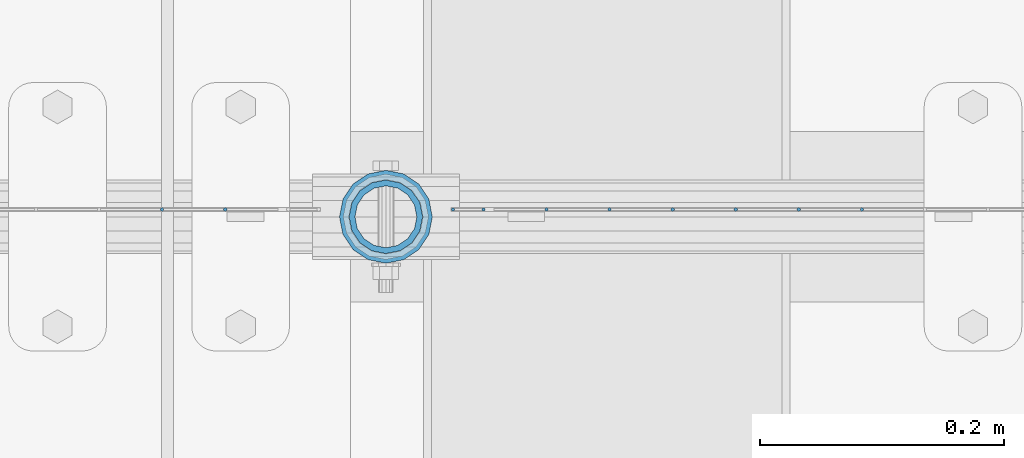
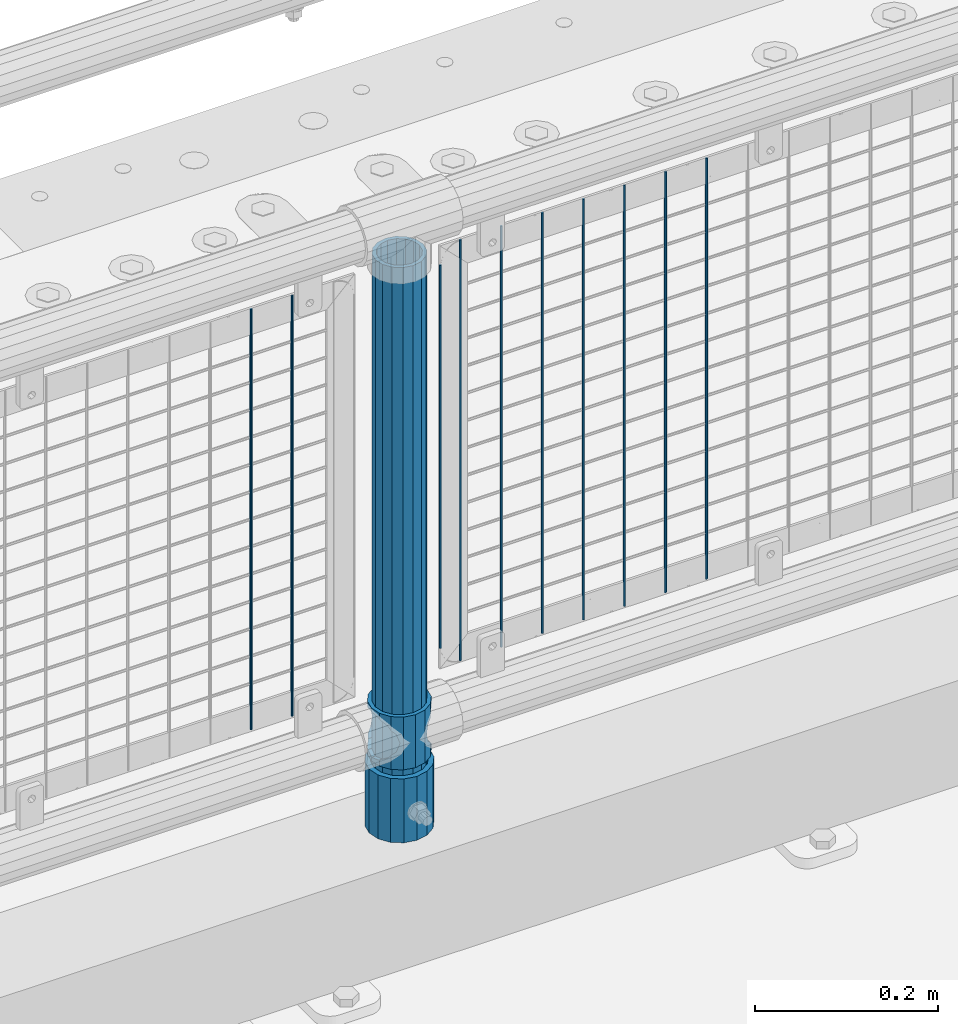
# One storey, part 86 of 219: 13 columns.
"""IFC2X3 building model written with IfcOpenShell, lengths in millimetres."""

from ifc_helpers import new_model, si_unit, frame, origin_with_axes, place, context, subcontext, project, spatial, faceted_brep, material, type_object, element, save


model = new_model("IFC2X3")

# Units and contexts
model_context = context("Model", 3, precision=1e-05, world=origin_with_axes())
body_context = subcontext(model_context, "Body", "Model", "MODEL_VIEW")
ifc_project = project(units=[si_unit("LENGTHUNIT", "METRE", prefix="MILLI"), si_unit("AREAUNIT", "SQUARE_METRE"), si_unit("VOLUMEUNIT", "CUBIC_METRE"), si_unit("MASSUNIT", "GRAM", prefix="KILO"), si_unit("TIMEUNIT", "SECOND"), si_unit("PLANEANGLEUNIT", "RADIAN"), si_unit("SOLIDANGLEUNIT", "STERADIAN"), si_unit("THERMODYNAMICTEMPERATUREUNIT", "DEGREE_CELSIUS"), si_unit("LUMINOUSINTENSITYUNIT", "LUMEN")], contexts=[model_context])

# Site, building, storey
site_placement = place(None, origin_with_axes())
site = spatial("IfcSite", under=ifc_project, at=site_placement, CompositionType="ELEMENT")
building_placement = place(site_placement, origin_with_axes())
building = spatial("IfcBuilding", under=site, at=building_placement, Name="Standard", CompositionType="ELEMENT")
storey_placement = place(building_placement, origin_with_axes())
storey = spatial("IfcBuildingStorey", under=building, at=storey_placement, Name="Undefined", CompositionType="ELEMENT", Elevation=0.0)

# Columns
ifc_material_1 = material(Name="Misc_Undefined")
column_type_1 = type_object("IfcColumnType", PredefinedType="NOTDEFINED")
column_1_placement = place(storey_placement, frame((10569.0, 31664.5, 263.02), z_axis=(-1.0, 0.0, 0.0), x_axis=(0.0, 0.0, 1.0)))
element("IfcColumn", 1, at=column_1_placement, inside=storey, type_object=column_type_1, material=ifc_material_1, context=body_context, shape_type="Brep", body=[
    faceted_brep([(56.6106908090114, 21.46069080901, -21.4606908090118), (56.6106908090114, 21.46069080901, -27.1226768591096), (61.9623795176703, 13.4513226476338, -32.4743655677721), (63.1897438117172, 11.614442172282, -32.8397438117172), (63.1897438117172, 11.614442172282, -28.0397438117179), (46.7644421722801, 28.0397438117179, -11.6144421722802), (46.7644421722801, 28.0397438117179, -20.0882031229849), (51.5310424080006, 24.8548033587067, -24.8548033587067), (35.1499999999996, 30.35, 0.0), (35.1499999999996, 30.3499999999985, -16.6306603983739), (23.5355578277192, 28.0397438117179, -11.6144421722802), (23.5355578277192, 28.0397438117179, -20.0882031229849), (13.6893091909879, 21.46069080901, -21.4606908090118), (13.6893091909879, 21.46069080901, -27.1226768591096), (18.7689575919987, 24.8548033587067, -24.8548033587067), (7.11025618828211, 11.614442172282, -28.0397438117179), (7.11025618828211, 11.614442172282, -32.8397438117172), (8.33762048232455, 13.4513226476338, -32.4743655677721), (4.79999999999961, 0.0, -30.3500000000004), (4.79999999999961, 0.0, -35.1499999999996), (7.11025618828211, -11.614442172282, -28.0397438117179), (7.11025618828211, -11.614442172282, -32.839743811719), (13.6893091909879, -21.46069080901, -21.4606908090118), (13.6893091909879, -21.46069080901, -27.1226768591077), (8.33762048232455, -13.4513226476338, -32.4743655677721), (23.5355578277191, -28.0397438117179, -11.6144421722802), (23.5355578277191, -28.0397438117179, -20.0882031229739), (18.7689575919921, -24.8548033587067, -24.8548033587067), (35.1499999999996, -30.35, 0.0), (35.1499999999996, -30.3499999999985, -16.6306603983649), (46.7644421722801, -28.0397438117179, -11.6144421722802), (46.7644421722801, -28.0397438117179, -20.0882031229739), (56.6106908090114, -21.46069080901, -21.4606908090118), (56.6106908090114, -21.46069080901, -27.1226768591077), (51.5310424080006, -24.8548033587067, -24.8548033587067), (63.1897438117172, -11.614442172282, -28.0397438117179), (63.1897438117172, -11.614442172282, -32.839743811719), (61.9623795176747, -13.4513226476338, -32.4743655677721), (65.4999999999997, 0.0, -30.3500000000004), (65.4999999999997, 0.0, -35.1499999999996), (0.0, -28.0397438117179, -11.6144421722802), (0.0, -30.3499999999985, 0.0), (0.0, -21.46069080901, -21.4606908090118), (0.0, -11.614442172282, -28.0397438117179), (0.0, 0.0, -30.3500000000004), (0.0, 11.614442172282, -28.0397438117179), (0.0, 21.46069080901, -21.4606908090118), (0.0, 28.0397438117179, -11.6144421722802), (0.0, 30.3499999999985, 0.0), (0.0, 28.0397438117179, 11.6144421722802), (23.5355578277192, 28.0397438117179, 11.6144421722806), (0.0, 21.46069080901, 21.4606908090118), (13.6893091909879, 21.46069080901, 21.4606908090118), (0.0, 11.614442172282, 28.0397438117179), (7.11025618828211, 11.614442172282, 28.0397438117175), (0.0, 0.0, 30.3500000000004), (4.79999999999961, 0.0, 30.3499999999999), (0.0, -11.614442172282, 28.0397438117179), (7.11025618828205, -11.614442172282, 28.0397438117175), (0.0, -21.46069080901, 21.4606908090118), (13.6893091909879, -21.46069080901, 21.4606908090118), (0.0, -28.0397438117179, 11.6144421722802), (23.5355578277191, -28.0397438117179, 11.6144421722806), (0.0, -32.4743655677703, 13.4513226476338), (0.0, -35.1500000000015, 0.0), (70.2999999999993, -35.1500000000015, 0.0), (70.2999999999993, -32.4743655677703, 13.4513226476338), (0.0, 13.4513226476338, -32.4743655677721), (0.0, 24.8548033587067, -24.8548033587067), (0.0, 0.0, -35.1500000000015), (0.0, -13.4513226476338, -32.4743655677721), (0.0, -24.8548033587067, -24.8548033587067), (0.0, -24.8548033587067, 24.8548033587067), (0.0, -13.4513226476338, 32.4743655677721), (0.0, 0.0, 35.1500000000015), (0.0, 13.4513226476338, 32.4743655677721), (0.0, 24.8548033587067, 24.8548033587067), (0.0, 32.4743655677703, 13.4513226476338), (0.0, 35.1500000000015, 0.0), (0.0, 32.4743655677703, -13.4513226476338), (0.0, -32.4743655677703, -13.4513226476338), (70.2999999999993, 32.4743655677703, 13.4513226476338), (70.2999999999993, 35.1500000000015, 0.0), (70.2999999999993, 32.4743655677703, -13.4513226476338), (70.2999999999993, 24.8548033587067, -24.8548033587067), (70.2999999999993, 13.4513226476338, -32.4743655677721), (70.2999999999993, 0.0, -35.1499999999996), (70.2999999999993, -13.4513226476338, -32.4743655677721), (70.2999999999993, -24.8548033587067, -24.8548033587067), (70.2999999999993, -32.4743655677703, -13.4513226476338), (70.2999999999993, 28.0397438117179, 11.6144421722802), (70.2999999999993, 21.46069080901, 21.4606908090118), (56.6106908090114, 21.46069080901, 21.4606908090118), (46.7644421722801, 28.0397438117179, 11.6144421722806), (70.2999999999993, 11.614442172282, 28.0397438117179), (63.1897438117172, 11.614442172282, 28.0397438117175), (70.2999999999993, 0.0, 30.3500000000004), (65.4999999999997, 0.0, 30.3499999999999), (70.2999999999993, -11.614442172282, 28.0397438117179), (63.1897438117172, -11.614442172282, 28.0397438117175), (70.2999999999993, -21.46069080901, 21.4606908090118), (56.6106908090114, -21.46069080901, 21.4606908090118), (70.2999999999993, -28.0397438117179, 11.6144421722802), (46.7644421722801, -28.0397438117179, 11.6144421722806), (70.2999999999993, -11.614442172282, -28.0397438117179), (70.2999999999993, 0.0, -30.3500000000004), (70.2999999999993, -21.46069080901, -21.4606908090118), (70.2999999999993, -28.0397438117179, -11.6144421722802), (70.2999999999993, -30.3499999999985, 0.0), (70.2999999999993, 24.8548033587067, 24.8548033587067), (70.2999999999993, 13.4513226476338, 32.4743655677721), (70.2999999999993, 0.0, 35.1499999999996), (70.2999999999993, -13.4513226476338, 32.4743655677721), (70.2999999999993, -24.8548033587067, 24.8548033587067), (70.2999999999993, 30.3499999999985, 0.0), (70.2999999999993, 28.0397438117179, -11.6144421722802), (70.2999999999993, 21.46069080901, -21.4606908090118), (70.2999999999993, 11.614442172282, -28.0397438117179), (61.9623795176742, 13.4513226476338, 32.4743655677717), (51.5310424080006, 24.8548033587067, 24.8548033587072), (56.6106908090114, 21.46069080901, 27.1226768591059), (65.4999999999997, 0.0, 35.1500000000001), (63.1897438117172, 11.614442172282, 32.8397438117177), (63.1897438117172, -11.614442172282, 32.8397438117177), (61.9623795176742, -13.4513226476338, 32.4743655677717), (56.6106908090114, -21.46069080901, 27.1226768591087), (51.5310424080006, -24.8548033587067, 24.8548033587072), (18.7689575919921, -24.8548033587067, 24.8548033587072), (46.7644421722801, -28.0397438117179, 20.0882031229862), (35.1499999999996, -30.3499999999985, 16.630660398373), (23.5355578277191, -28.0397438117179, 20.0882031229862), (8.33762048232506, -13.4513226476338, 32.4743655677717), (13.6893091909879, -21.46069080901, 27.1226768591087), (4.79999999999961, 0.0, 35.1500000000001), (7.11025618828205, -11.614442172282, 32.8397438117177), (7.11025618828211, 11.614442172282, 32.8397438117177), (8.33762048232069, 13.4513226476338, 32.4743655677717), (13.6893091909879, 21.46069080901, 27.1226768591059), (18.7689575919987, 24.8548033587067, 24.8548033587072), (23.5355578277192, 28.0397438117179, 20.0882031229794), (35.1499999999996, 30.3499999999985, 16.6306603983667), (46.7644421722801, 28.0397438117179, 20.0882031229794)], [[[0, 1, 2, 3, 4]], [[5, 6, 7, 1, 0]], [[8, 9, 6, 5]], [[10, 11, 9, 8]], [[12, 13, 14, 11, 10]], [[15, 16, 17, 13, 12]], [[18, 19, 16, 15]], [[20, 21, 19, 18]], [[22, 23, 24, 21, 20]], [[25, 26, 27, 23, 22]], [[28, 29, 26, 25]], [[30, 31, 29, 28]], [[32, 33, 34, 31, 30]], [[35, 36, 37, 33, 32]], [[38, 39, 36, 35]], [[4, 3, 39, 38]], [[40, 41, 28, 25]], [[42, 40, 25, 22]], [[43, 42, 22, 20]], [[44, 43, 20, 18]], [[45, 44, 18, 15]], [[46, 45, 15, 12]], [[47, 46, 12, 10]], [[48, 47, 10, 8]], [[49, 48, 8, 50]], [[51, 49, 50, 52]], [[53, 51, 52, 54]], [[55, 53, 54, 56]], [[57, 55, 56, 58]], [[59, 57, 58, 60]], [[61, 59, 60, 62]], [[41, 61, 62, 28]], [[63, 64, 65, 66]], [[17, 67, 68, 14, 13]], [[19, 69, 67, 17, 16]], [[70, 69, 19, 21, 24]], [[71, 70, 24, 23, 27]], [[63, 72, 73, 74, 75, 76, 77, 78, 79, 68, 67, 69, 70, 71, 80, 64], [40, 42, 43, 44, 45, 46, 47, 48, 49, 51, 53, 55, 57, 59, 61, 41]], [[78, 77, 81, 82]], [[79, 78, 82, 83]], [[14, 68, 79, 83, 84, 7, 6, 9, 11]], [[84, 85, 2, 1, 7]], [[85, 86, 39, 3, 2]], [[37, 87, 88, 34, 33]], [[39, 86, 87, 37, 36]], [[34, 88, 89, 80, 71, 27, 26, 29, 31]], [[64, 80, 89, 65]], [[90, 91, 92, 93]], [[91, 94, 95, 92]], [[94, 96, 97, 95]], [[96, 98, 99, 97]], [[98, 100, 101, 99]], [[100, 102, 103, 101]], [[104, 105, 38, 35]], [[106, 104, 35, 32]], [[107, 106, 32, 30]], [[108, 107, 30, 28]], [[102, 108, 28, 103]], [[88, 87, 86, 85, 84, 83, 82, 81, 109, 110, 111, 112, 113, 66, 65, 89], [100, 98, 96, 94, 91, 90, 114, 115, 116, 117, 105, 104, 106, 107, 108, 102]], [[118, 110, 109, 119, 120]], [[121, 111, 110, 118, 122]], [[112, 111, 121, 123, 124]], [[113, 112, 124, 125, 126]], [[127, 72, 63, 66, 113, 126, 128, 129, 130]], [[131, 73, 72, 127, 132]], [[133, 74, 73, 131, 134]], [[75, 74, 133, 135, 136]], [[76, 75, 136, 137, 138]], [[119, 109, 81, 77, 76, 138, 139, 140, 141]], [[92, 120, 119, 141, 93]], [[95, 122, 118, 120, 92]], [[97, 121, 122, 95]], [[99, 123, 121, 97]], [[101, 125, 124, 123, 99]], [[103, 128, 126, 125, 101]], [[28, 129, 128, 103]], [[62, 130, 129, 28]], [[60, 132, 127, 130, 62]], [[58, 134, 131, 132, 60]], [[56, 133, 134, 58]], [[54, 135, 133, 56]], [[52, 137, 136, 135, 54]], [[50, 139, 138, 137, 52]], [[8, 140, 139, 50]], [[93, 141, 140, 8]], [[114, 90, 93, 8]], [[115, 114, 8, 5]], [[116, 115, 5, 0]], [[117, 116, 0, 4]], [[105, 117, 4, 38]]]),
])
ifc_material_2 = material()
column_type_2 = type_object("IfcColumnType", PredefinedType="NOTDEFINED")
column_2_placement = place(storey_placement, frame((10569.0, 31664.5, 168.02), z_axis=(-1.0, 0.0, 0.0), x_axis=(0.0, 0.0, 1.0)))
element("IfcColumn", 2, at=column_2_placement, inside=storey, type_object=column_type_2, material=ifc_material_2, context=body_context, shape_type="Brep", body=[
    faceted_brep([(0.0, -25.3499999999985, 0.0), (0.0, -23.4203461491597, 9.70102501045585), (760.0, -23.4203461491597, 9.70102501045585), (760.0, -25.3499999999985, 0.0), (0.0, -17.9251569030785, 17.9251569030785), (760.0, -17.9251569030785, 17.9251569030785), (0.0, -9.70102501045403, 23.4203461491616), (760.0, -9.70102501045403, 23.4203461491616), (0.0, 0.0, 25.3500000000004), (760.0, 0.0, 25.3500000000004), (0.0, 9.70102501045403, 23.4203461491616), (760.0, 9.70102501045403, 23.4203461491616), (0.0, 17.9251569030785, 17.9251569030785), (760.0, 17.9251569030785, 17.9251569030785), (0.0, 23.4203461491597, 9.70102501045585), (760.0, 23.4203461491597, 9.70102501045585), (0.0, 25.3499999999985, 0.0), (760.0, 25.3499999999985, 0.0), (0.0, 23.4203461491597, -9.70102501045585), (760.0, 23.4203461491597, -9.70102501045585), (0.0, 17.9251569030785, -17.9251569030785), (760.0, 17.9251569030785, -17.9251569030785), (0.0, 9.70102501045403, -23.4203461491616), (760.0, 9.70102501045403, -23.4203461491616), (0.0, 0.0, -25.3500000000004), (760.0, 0.0, -25.3500000000004), (0.0, -9.70102501045403, -23.4203461491616), (760.0, -9.70102501045403, -23.4203461491616), (0.0, -17.9251569030785, -17.9251569030785), (760.0, -17.9251569030785, -17.9251569030785), (0.0, -23.4203461491597, -9.70102501045585), (760.0, -23.4203461491597, -9.70102501045585), (0.0, -30.1500000000015, 0.0), (0.0, -27.8549679052157, -11.5379054858076), (760.0, -27.8549679052157, -11.5379054858076), (760.0, -30.1500000000015, 0.0), (0.0, -21.3192694527752, -21.3192694527752), (760.0, -21.3192694527752, -21.3192694527752), (0.0, -11.5379054858058, -27.8549679052157), (760.0, -11.5379054858058, -27.8549679052157), (0.0, 0.0, -30.1499999999996), (760.0, 0.0, -30.1499999999996), (0.0, 11.5379054858058, -27.8549679052157), (760.0, 11.5379054858058, -27.8549679052157), (0.0, 21.3192694527752, -21.3192694527752), (760.0, 21.3192694527752, -21.3192694527752), (0.0, 27.8549679052157, -11.5379054858076), (760.0, 27.8549679052157, -11.5379054858076), (0.0, 30.1500000000015, 0.0), (760.0, 30.1500000000015, 0.0), (0.0, 27.8549679052157, 11.5379054858076), (760.0, 27.8549679052157, 11.5379054858076), (0.0, 21.3192694527752, 21.3192694527752), (760.0, 21.3192694527752, 21.3192694527752), (0.0, 11.5379054858058, 27.8549679052157), (760.0, 11.5379054858058, 27.8549679052157), (0.0, 0.0, 30.1499999999996), (760.0, 0.0, 30.1499999999996), (0.0, -11.5379054858058, 27.8549679052157), (760.0, -11.5379054858058, 27.8549679052157), (0.0, -21.3192694527752, 21.3192694527752), (760.0, -21.3192694527752, 21.3192694527752), (0.0, -27.8549679052157, 11.5379054858076), (760.0, -27.8549679052157, 11.5379054858076)], [[[0, 1, 2, 3]], [[1, 4, 5, 2]], [[4, 6, 7, 5]], [[6, 8, 9, 7]], [[8, 10, 11, 9]], [[10, 12, 13, 11]], [[12, 14, 15, 13]], [[14, 16, 17, 15]], [[16, 18, 19, 17]], [[18, 20, 21, 19]], [[20, 22, 23, 21]], [[22, 24, 25, 23]], [[24, 26, 27, 25]], [[26, 28, 29, 27]], [[28, 30, 31, 29]], [[30, 0, 3, 31]], [[32, 33, 34, 35]], [[33, 36, 37, 34]], [[36, 38, 39, 37]], [[38, 40, 41, 39]], [[40, 42, 43, 41]], [[42, 44, 45, 43]], [[44, 46, 47, 45]], [[46, 48, 49, 47]], [[48, 50, 51, 49]], [[50, 52, 53, 51]], [[52, 54, 55, 53]], [[54, 56, 57, 55]], [[56, 58, 59, 57]], [[58, 60, 61, 59]], [[60, 62, 63, 61]], [[62, 32, 35, 63]], [[37, 39, 41, 43, 45, 47, 49, 51, 53, 55, 57, 59, 61, 63, 35, 34], [5, 7, 9, 11, 13, 15, 17, 19, 21, 23, 25, 27, 29, 31, 3, 2]], [[62, 60, 58, 56, 54, 52, 50, 48, 46, 44, 42, 40, 38, 36, 33, 32], [30, 28, 26, 24, 22, 20, 18, 16, 14, 12, 10, 8, 6, 4, 1, 0]]]),
])
column_type_3 = type_object("IfcColumnType", PredefinedType="NOTDEFINED")
column_3_placement = place(storey_placement, frame((10569.0, 31664.5, 168.02), z_axis=(0.0, 1.0, 0.0), x_axis=(0.0, 0.0, 1.0)))
element("IfcColumn", 3, at=column_3_placement, inside=storey, type_object=column_type_3, material=ifc_material_2, context=body_context, shape_type="Brep", body=[
    faceted_brep([(0.0, -31.75, 0.0), (0.0, -29.3331751572332, 12.1501989775934), (85.0, -29.3331751572332, 12.1501989775934), (85.0, -31.75, 0.0), (0.0, -22.4506403026735, 22.4506403026717), (85.0, -22.4506403026735, 22.4506403026717), (0.0, -12.1501989775916, 29.3331751572332), (85.0, -12.1501989775916, 29.3331751572332), (0.0, 0.0, 31.75), (85.0, 0.0, 31.75), (0.0, 12.1501989775916, 29.3331751572332), (85.0, 12.1501989775916, 29.3331751572332), (0.0, 22.4506403026735, 22.4506403026717), (85.0, 22.4506403026735, 22.4506403026717), (0.0, 29.3331751572332, 12.1501989775934), (85.0, 29.3331751572332, 12.1501989775934), (0.0, 31.75, 0.0), (85.0, 31.75, 0.0), (0.0, 29.3331751572332, -12.1501989775934), (85.0, 29.3331751572332, -12.1501989775934), (0.0, 22.4506403026735, -22.4506403026717), (85.0, 22.4506403026735, -22.4506403026717), (0.0, 12.1501989775916, -29.3331751572332), (85.0, 12.1501989775916, -29.3331751572332), (0.0, 0.0, -31.75), (85.0, 0.0, -31.75), (0.0, -12.1501989775916, -29.3331751572332), (85.0, -12.1501989775916, -29.3331751572332), (0.0, -22.4506403026735, -22.4506403026717), (85.0, -22.4506403026735, -22.4506403026717), (0.0, -29.3331751572332, -12.1501989775934), (85.0, -29.3331751572332, -12.1501989775934), (0.0, -38.0499999999993, 0.0), (0.0, -35.1536162120537, -14.5611046014928), (85.0, -35.1536162120537, -14.5611046014928), (85.0, -38.0499999999993, 0.0), (0.0, -26.9054130241475, -26.9054130241493), (85.0, -26.9054130241475, -26.9054130241493), (0.0, -14.561104601491, -35.1536162120537), (85.0, -14.561104601491, -35.1536162120537), (0.0, 0.0, -38.0499999999993), (85.0, 0.0, -38.0499999999993), (0.0, 14.561104601491, -35.1536162120537), (85.0, 14.561104601491, -35.1536162120537), (0.0, 26.9054130241475, -26.9054130241493), (85.0, 26.9054130241475, -26.9054130241493), (0.0, 35.1536162120537, -14.5611046014928), (85.0, 35.1536162120537, -14.5611046014928), (0.0, 38.0499999999993, 0.0), (85.0, 38.0499999999993, 0.0), (0.0, 35.1536162120537, 14.5611046014928), (85.0, 35.1536162120537, 14.5611046014928), (0.0, 26.9054130241475, 26.9054130241493), (85.0, 26.9054130241475, 26.9054130241493), (0.0, 14.561104601491, 35.1536162120537), (85.0, 14.561104601491, 35.1536162120537), (0.0, 0.0, 38.0499999999993), (85.0, 0.0, 38.0499999999993), (0.0, -14.561104601491, 35.1536162120537), (85.0, -14.561104601491, 35.1536162120537), (0.0, -26.9054130241475, 26.9054130241493), (85.0, -26.9054130241475, 26.9054130241493), (0.0, -35.1536162120537, 14.5611046014928), (85.0, -35.1536162120537, 14.5611046014928)], [[[0, 1, 2, 3]], [[1, 4, 5, 2]], [[4, 6, 7, 5]], [[6, 8, 9, 7]], [[8, 10, 11, 9]], [[10, 12, 13, 11]], [[12, 14, 15, 13]], [[14, 16, 17, 15]], [[16, 18, 19, 17]], [[18, 20, 21, 19]], [[20, 22, 23, 21]], [[22, 24, 25, 23]], [[24, 26, 27, 25]], [[26, 28, 29, 27]], [[28, 30, 31, 29]], [[30, 0, 3, 31]], [[32, 33, 34, 35]], [[33, 36, 37, 34]], [[36, 38, 39, 37]], [[38, 40, 41, 39]], [[40, 42, 43, 41]], [[42, 44, 45, 43]], [[44, 46, 47, 45]], [[46, 48, 49, 47]], [[48, 50, 51, 49]], [[50, 52, 53, 51]], [[52, 54, 55, 53]], [[54, 56, 57, 55]], [[56, 58, 59, 57]], [[58, 60, 61, 59]], [[60, 62, 63, 61]], [[62, 32, 35, 63]], [[37, 39, 41, 43, 45, 47, 49, 51, 53, 55, 57, 59, 61, 63, 35, 34], [5, 7, 9, 11, 13, 15, 17, 19, 21, 23, 25, 27, 29, 31, 3, 2]], [[62, 60, 58, 56, 54, 52, 50, 48, 46, 44, 42, 40, 38, 36, 33, 32], [30, 28, 26, 24, 22, 20, 18, 16, 14, 12, 10, 8, 6, 4, 1, 0]]]),
])
column_type_4 = type_object("IfcColumnType", Name="D3", PredefinedType="NOTDEFINED")
for number, where, z_axis, x_axis in (
    (4, (10958.93, 31670.5, 353.020000000001), (-1.0, 0.0, 0.0), (0.0, 0.0, 1.0)),
    (5, (10907.275, 31670.5, 353.020000000001), (-1.0, 0.0, 0.0), (0.0, 0.0, 1.0)),
    (6, (10855.62, 31670.5, 353.020000000001), (-1.0, 0.0, 0.0), (0.0, 0.0, 1.0)),
    (7, (10803.965, 31670.5, 353.020000000001), (-1.0, 0.0, 0.0), (0.0, 0.0, 1.0)),
    (8, (10752.31, 31670.5, 353.020000000001), (-1.0, 0.0, 0.0), (0.0, 0.0, 1.0)),
    (9, (10700.655, 31670.5, 353.020000000001), (-1.0, 0.0, 0.0), (0.0, 0.0, 1.0)),
):
    element("IfcColumn", number, at=place(storey_placement, frame(where, z_axis=z_axis, x_axis=x_axis)), inside=storey, type_object=column_type_4, material=ifc_material_1, ObjectType="D3", context=body_context, shape_type="Brep", body=[
        faceted_brep([(0.0, -1.5, -5.6843418860808e-14), (0.0, -0.75, -1.29903810567669), (560.0, -0.75, -1.29903810567703), (560.0, -1.5, 0.0), (0.0, 0.75, -1.29903810567669), (560.0, 0.75, -1.29903810567703), (0.0, 1.5, -5.6843418860808e-14), (560.0, 1.5, 0.0), (0.0, 0.75, 1.29903810567669), (560.0, 0.75, 1.29903810567703), (0.0, -0.75, 1.29903810567669), (560.0, -0.75, 1.29903810567703)], [[[0, 1, 2, 3]], [[1, 4, 5, 2]], [[4, 6, 7, 5]], [[6, 8, 9, 7]], [[8, 10, 11, 9]], [[10, 0, 3, 11]], [[5, 7, 9, 11, 3, 2]], [[10, 8, 6, 4, 1, 0]]]),
    ])
column_4_placement = place(storey_placement, frame((10624.0, 31670.5, 378.020000000001), z_axis=(-1.0, 0.0, 0.0), x_axis=(0.0, 0.0, 1.0)))
element("IfcColumn", 10, at=column_4_placement, inside=storey, type_object=column_type_4, material=ifc_material_1, ObjectType="D3", context=body_context, shape_type="Brep", body=[
    faceted_brep([(0.0, -1.5, -5.6843418860808e-14), (0.0, -0.75, -1.29903810567669), (510.0, -0.75, -1.29903810567703), (510.0, -1.5, 0.0), (0.0, 0.75, -1.29903810567669), (510.0, 0.75, -1.29903810567703), (0.0, 1.5, -5.6843418860808e-14), (510.0, 1.5, 0.0), (0.0, 0.75, 1.29903810567669), (510.0, 0.75, 1.29903810567703), (0.0, -0.75, 1.29903810567669), (510.0, -0.75, 1.29903810567703)], [[[0, 1, 2, 3]], [[1, 4, 5, 2]], [[4, 6, 7, 5]], [[6, 8, 9, 7]], [[8, 10, 11, 9]], [[10, 0, 3, 11]], [[5, 7, 9, 11, 3, 2]], [[10, 8, 6, 4, 1, 0]]]),
])
for number, where, z_axis, x_axis in (
    (11, (10649.0, 31670.5, 353.020000000001), (-1.0, 0.0, 0.0), (0.0, 0.0, 1.0)),
    (12, (10437.34, 31670.5, 353.020000000001), (-1.0, 0.0, 0.0), (0.0, 0.0, 1.0)),
    (13, (10385.685, 31670.5, 353.020000000001), (-1.0, 0.0, 0.0), (0.0, 0.0, 1.0)),
):
    element("IfcColumn", number, at=place(storey_placement, frame(where, z_axis=z_axis, x_axis=x_axis)), inside=storey, type_object=column_type_4, material=ifc_material_1, ObjectType="D3", context=body_context, shape_type="Brep", body=[
        faceted_brep([(0.0, -1.5, -5.6843418860808e-14), (0.0, -0.75, -1.29903810567669), (560.0, -0.75, -1.29903810567703), (560.0, -1.5, 0.0), (0.0, 0.75, -1.29903810567669), (560.0, 0.75, -1.29903810567703), (0.0, 1.5, -5.6843418860808e-14), (560.0, 1.5, 0.0), (0.0, 0.75, 1.29903810567669), (560.0, 0.75, 1.29903810567703), (0.0, -0.75, 1.29903810567669), (560.0, -0.75, 1.29903810567703)], [[[0, 1, 2, 3]], [[1, 4, 5, 2]], [[4, 6, 7, 5]], [[6, 8, 9, 7]], [[8, 10, 11, 9]], [[10, 0, 3, 11]], [[5, 7, 9, 11, 3, 2]], [[10, 8, 6, 4, 1, 0]]]),
    ])

save(model, "model.ifc")
